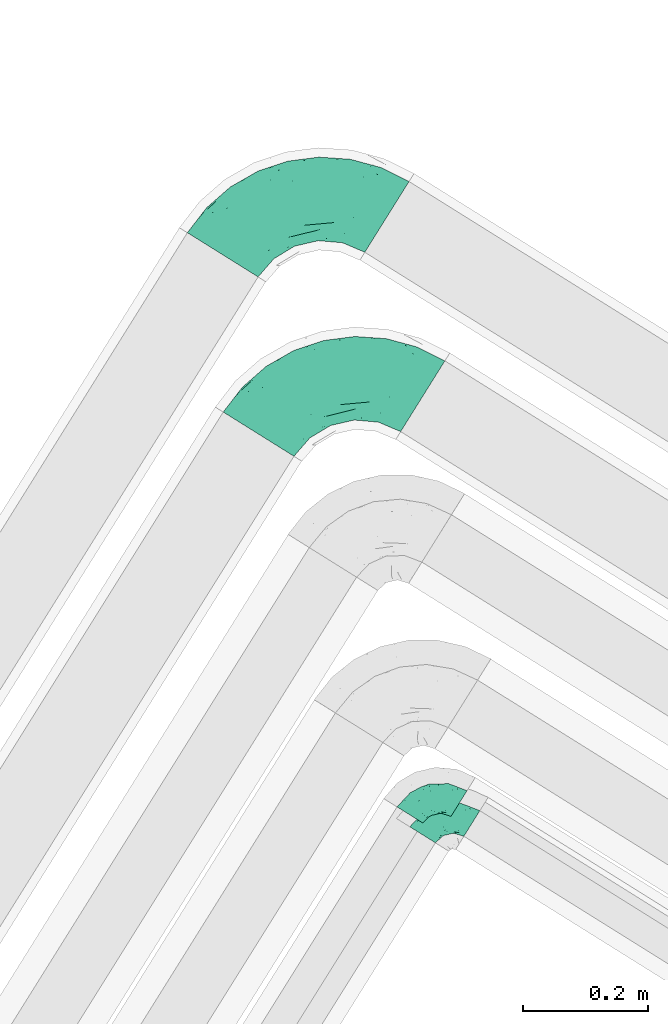
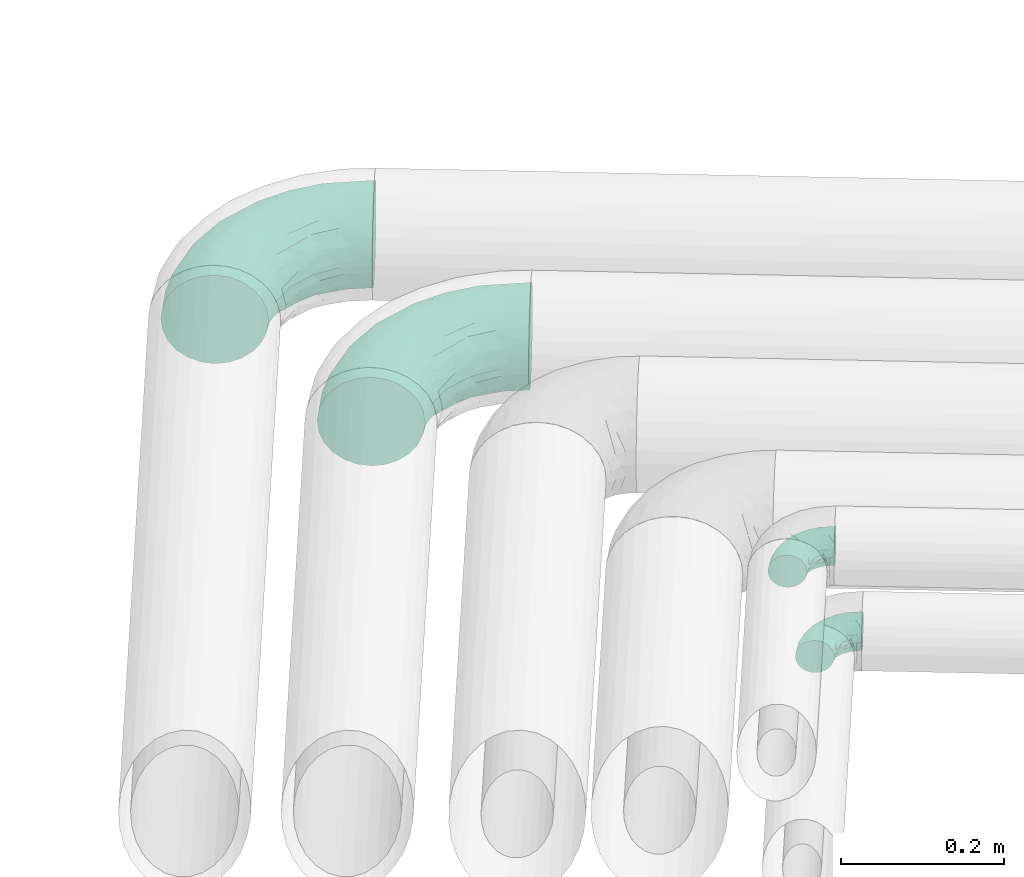
# One storey, part 63 of 93: 4 flow fittings.
"""IFC2X3 building model written with IfcOpenShell, lengths in millimetres."""

import ifcopenshell
import ifcopenshell.guid

model = None  # the IFC model being written
_history = None  # IfcOwnerHistory: only IFC2X3 demands one
_inside = {}  # id of a spatial element -> (the spatial element, [elements in it])
_under = {}  # id of a project, library or spatial element -> (it, [spatial elements below it])
_declared = {}  # id of a project -> (the project, [libraries it declares])
_typed = {}  # id of a type object -> (the type object, [elements of that type])
_made_of = {}  # id of a material, layer set ... -> (it, [elements and type objects made of it])


def new_model(schema):
    """Start an empty IFC model of exactly this schema.

    Asked for "IFC4X3", IfcOpenShell would pick the latest addendum, in which some entities
    have other attributes; the version numbers below select the first issue.
    IFC2X3 requires an IfcOwnerHistory on every rooted entity: one is made here for all.
    """
    global model, _history
    if schema == "IFC4X3":
        model = ifcopenshell.file(schema_version=(4, 3, 0, 0))
    else:
        model = ifcopenshell.file(schema=schema)
    _inside.clear()
    _under.clear()
    _declared.clear()
    _typed.clear()
    _made_of.clear()
    _history = None
    if model.schema == "IFC2X3":
        org = make("IfcOrganization", Name="unknown")
        user = make(
            "IfcPersonAndOrganization",
            ThePerson=make("IfcPerson", FamilyName="unknown"),
            TheOrganization=org,
        )
        app = make(
            "IfcApplication",
            ApplicationDeveloper=org,
            Version="unknown",
            ApplicationFullName="unknown",
            ApplicationIdentifier="unknown",
        )
        _history = make(
            "IfcOwnerHistory",
            OwningUser=user,
            OwningApplication=app,
            ChangeAction="ADDED",
            CreationDate=0,
        )
    return model


def make(cls, **values):
    """One entity of the class cls with the attributes given. An attribute that is None is left unset."""
    return model.create_entity(
        cls, **{name: value for name, value in values.items() if value is not None}
    )


def entity(cls, *values):
    """Any entity or typed value of the class cls, its attributes in the order of the schema. None: left unset."""
    e = model.create_entity(cls)
    for i, value in enumerate(values):
        if value is not None:
            e[i] = value
    return e


def rooted(cls, **values):
    """An entity with a GlobalId (a new one), such as an element, a storey or a relation."""
    return make(cls, GlobalId=ifcopenshell.guid.new(), OwnerHistory=_history, **values)


def si_unit(unit_type, name, prefix=None):
    """IfcSIUnit, for example si_unit("LENGTHUNIT", "METRE", prefix="MILLI")."""
    return make("IfcSIUnit", UnitType=unit_type, Prefix=prefix, Name=name)


def converted_unit(unit_type, name, factor, base, dimensions=None, offset=None):
    """IfcConversionBasedUnit, such as the inch: factor (a typed value) times the base unit."""
    return make(
        "IfcConversionBasedUnit"
        if offset is None
        else "IfcConversionBasedUnitWithOffset",
        ConversionOffset=offset,
        Dimensions=None
        if dimensions is None
        else entity("IfcDimensionalExponents", *dimensions),
        UnitType=unit_type,
        Name=name,
        ConversionFactor=make(
            "IfcMeasureWithUnit", ValueComponent=factor, UnitComponent=base
        ),
    )


def derived_unit(unit_type, elements):
    """IfcDerivedUnit: a product of units, each with its exponent."""
    return make(
        "IfcDerivedUnit",
        Elements=[
            make("IfcDerivedUnitElement", Unit=unit, Exponent=power)
            for unit, power in elements
        ],
        UnitType=unit_type,
    )


def assignment(units):
    """IfcUnitAssignment: the units of a project."""
    return None if units is None else make("IfcUnitAssignment", Units=units)


def point(xyz):
    """IfcCartesianPoint."""
    return None if xyz is None else make("IfcCartesianPoint", Coordinates=xyz)


def direction(xyz):
    """IfcDirection."""
    return None if xyz is None else make("IfcDirection", DirectionRatios=xyz)


def frame(location, z_axis=None, x_axis=None):
    """IfcAxis2Placement3D, a coordinate frame: its origin and axes. An axis left out is left unset."""
    return make(
        "IfcAxis2Placement3D",
        Location=point(location),
        Axis=direction(z_axis),
        RefDirection=direction(x_axis),
    )


def origin():
    """The frame at (0, 0, 0) with its axes left unset."""
    return frame((0.0, 0.0, 0.0))


def place(relative_to, where):
    """IfcLocalPlacement: puts the frame where relative to a parent placement (None: the world)."""
    return make(
        "IfcLocalPlacement", PlacementRelTo=relative_to, RelativePlacement=where
    )


def context(
    kind, dimensions, precision=None, world=None, true_north=None, identifier=None
):
    """IfcGeometricRepresentationContext, for example the 3D "Model" context."""
    return make(
        "IfcGeometricRepresentationContext",
        ContextIdentifier=identifier,
        ContextType=kind,
        CoordinateSpaceDimension=dimensions,
        Precision=precision,
        WorldCoordinateSystem=world,
        TrueNorth=true_north,
    )


def subcontext(parent, identifier, kind, view, scale=None):
    """IfcGeometricRepresentationSubContext, for example "Body" below "Model"."""
    return make(
        "IfcGeometricRepresentationSubContext",
        ContextIdentifier=identifier,
        ContextType=kind,
        ParentContext=parent,
        TargetScale=scale,
        TargetView=view,
    )


def project(units=None, contexts=None):
    """IfcProject with its units and contexts."""
    return rooted(
        "IfcProject",
        Name="project",
        RepresentationContexts=contexts,
        UnitsInContext=assignment(units),
    )


def spatial(cls, under=None, at=None, **own):
    """A site, building, storey or space (cls), placed at a placement, below another one or the project."""
    s = rooted(cls, ObjectPlacement=at, **own)
    if under is not None:
        _under.setdefault(under.id(), (under, []))[1].append(s)
    return s


def faces_of(points, faces, orient=None, outer=None):
    """IfcFace entities. A face is a list of loops; a loop is a list of indices into points, from 0.

    orient and outer hold one flag for each loop. By default every Orientation is true, the
    first loop of a face is its IfcFaceOuterBound and the others are IfcFaceBound.
    """
    made = []
    for i, loops in enumerate(faces):
        bounds = []
        for j, loop in enumerate(loops):
            is_outer = j == 0 if outer is None else outer[i][j]
            bounds.append(
                make(
                    "IfcFaceOuterBound" if is_outer else "IfcFaceBound",
                    Bound=make("IfcPolyLoop", Polygon=[points[k] for k in loop]),
                    Orientation=True if orient is None else orient[i][j],
                )
            )
        made.append(make("IfcFace", Bounds=bounds))
    return made


def faceted_brep(points, faces, orient=None, outer=None, voids=None):
    """IfcFacetedBrep: a solid bounded by flat faces; with voids (closed shells), ...WithVoids."""
    shared = [point(p) for p in points]
    hull = make("IfcClosedShell", CfsFaces=faces_of(shared, faces, orient, outer))
    if voids is None:
        return make("IfcFacetedBrep", Outer=hull)
    return make(
        "IfcFacetedBrepWithVoids",
        Outer=hull,
        Voids=[
            make(cls, CfsFaces=faces_of(shared, fs, o, b)) for cls, fs, o, b in voids
        ],
    )


def shape(context_of_items, identifier, shape_type, items):
    """IfcShapeRepresentation: the items that make up one representation, for example the "Body"."""
    return make(
        "IfcShapeRepresentation",
        ContextOfItems=context_of_items,
        RepresentationIdentifier=identifier,
        RepresentationType=shape_type,
        Items=items,
    )


def source(mapping_origin, context_of_items, identifier, shape_type, items):
    """IfcRepresentationMap: a shape defined once, which mapped items show again and again."""
    return make(
        "IfcRepresentationMap",
        MappingOrigin=mapping_origin,
        MappedRepresentation=shape(context_of_items, identifier, shape_type, items),
    )


def transform(
    local_origin,
    x_axis=None,
    y_axis=None,
    z_axis=None,
    scale=None,
    scale2=None,
    scale3=None,
    uniform=True,
):
    """IfcCartesianTransformationOperator3D, or its non-uniform kind. x_axis, y_axis, z_axis: its Axis1, 2, 3."""
    if uniform:
        return make(
            "IfcCartesianTransformationOperator3D",
            Axis1=direction(x_axis),
            Axis2=direction(y_axis),
            LocalOrigin=point(local_origin),
            Scale=scale,
            Axis3=direction(z_axis),
        )
    return make(
        "IfcCartesianTransformationOperator3DnonUniform",
        Axis1=direction(x_axis),
        Axis2=direction(y_axis),
        LocalOrigin=point(local_origin),
        Scale=scale,
        Axis3=direction(z_axis),
        Scale2=scale2,
        Scale3=scale3,
    )


def mapped(mapping_source, mapping_target):
    """IfcMappedItem: shows the shape of a source again, moved by a transform."""
    return make(
        "IfcMappedItem", MappingSource=mapping_source, MappingTarget=mapping_target
    )


def material(Name=None, Category=None):
    """IfcMaterial."""
    return make("IfcMaterial", Name=Name, Category=Category)


def made_of(thing, what):
    """Note that an element or type object is made of a material, layer set ...; save() writes the relation."""
    if what is not None:
        _made_of.setdefault(what.id(), (what, []))[1].append(thing)
    return thing


def type_object(cls, material=None, **own):
    """A type object (cls), such as IfcWallType, which elements share."""
    return made_of(rooted(cls, **own), material)


def type_shapes(of_type, sources):
    """Give a type object the sources (RepresentationMaps) that its elements show as mapped items."""
    of_type.RepresentationMaps = sources


def element(
    cls,
    number,
    at=None,
    inside=None,
    cuts=None,
    type_object=None,
    material=None,
    context=None,
    identifier="Body",
    shape_type=None,
    held_by="IfcProductDefinitionShape",
    body=None,
    shapes=None,
    **own,
):
    """One element of the class cls, such as IfcWall. Its Tag is "e" and its number.

    at: its placement. inside: the storey or other place that contains it. cuts: it is an
    opening in that element (IfcRelVoidsElement). A single representation is given by context,
    identifier, shape_type and body (its items); several are given by shapes. held_by: the class
    of the entity that holds the representations. save() writes the other relations.
    """
    e = rooted(cls, Tag="e%d" % number, ObjectPlacement=at, **own)
    if body is not None:
        shapes = [shape(context, identifier, shape_type, body)]
    if shapes is not None:
        e.Representation = make(held_by, Representations=shapes)
    if inside is not None:
        _inside.setdefault(inside.id(), (inside, []))[1].append(e)
    if cuts is not None:
        rooted(
            "IfcRelVoidsElement", RelatingBuildingElement=cuts, RelatedOpeningElement=e
        )
    if type_object is not None:
        _typed.setdefault(type_object.id(), (type_object, []))[1].append(e)
    return made_of(e, material)


def aggregate(whole, parts):
    """IfcRelAggregates: a whole, such as a stair, and the parts it consists of."""
    return rooted("IfcRelAggregates", RelatingObject=whole, RelatedObjects=parts)


def save(model, path):
    """Write the relations noted so far, then the file.

    IfcRelAggregates (storeys below a building ...), IfcRelContainedInSpatialStructure (elements
    in a storey), IfcRelDefinesByType, IfcRelAssociatesMaterial and IfcRelDeclares: one each for
    every whole, place, type object, material and project.
    """
    for whole, parts in _under.values():
        aggregate(whole, parts)
    for where, things in _inside.values():
        rooted(
            "IfcRelContainedInSpatialStructure",
            RelatedElements=things,
            RelatingStructure=where,
        )
    for kind, things in _typed.values():
        rooted("IfcRelDefinesByType", RelatedObjects=things, RelatingType=kind)
    for what, things in _made_of.values():
        rooted("IfcRelAssociatesMaterial", RelatedObjects=things, RelatingMaterial=what)
    for by, libraries in _declared.values():
        rooted("IfcRelDeclares", RelatingContext=by, RelatedDefinitions=libraries)
    model.write(path)


model = new_model("IFC2X3")

# Units and contexts
model_context = context("Model", 3, precision=0.01, world=origin(), true_north=direction((6.12303176911189e-17, 1.0)))
body_context = subcontext(model_context, "Body", "Model", "MODEL_VIEW")
ifc_project = project(units=[si_unit("LENGTHUNIT", "METRE", prefix="MILLI"), si_unit("AREAUNIT", "SQUARE_METRE"), si_unit("VOLUMEUNIT", "CUBIC_METRE"), converted_unit("PLANEANGLEUNIT", "DEGREE", entity("IfcRatioMeasure", 0.0174532925199433), si_unit("PLANEANGLEUNIT", "RADIAN"), dimensions=[0, 0, 0, 0, 0, 0, 0]), si_unit("MASSUNIT", "GRAM", prefix="KILO"), derived_unit("MASSDENSITYUNIT", [(si_unit("MASSUNIT", "GRAM", prefix="KILO"), 1), (si_unit("LENGTHUNIT", "METRE"), -3)]), derived_unit("MOMENTOFINERTIAUNIT", [(si_unit("LENGTHUNIT", "METRE"), 4)]), si_unit("TIMEUNIT", "SECOND"), si_unit("FREQUENCYUNIT", "HERTZ"), si_unit("THERMODYNAMICTEMPERATUREUNIT", "DEGREE_CELSIUS"), derived_unit("THERMALTRANSMITTANCEUNIT", [(si_unit("MASSUNIT", "GRAM", prefix="KILO"), 1), (si_unit("THERMODYNAMICTEMPERATUREUNIT", "KELVIN"), -1), (si_unit("TIMEUNIT", "SECOND"), -3)]), derived_unit("VOLUMETRICFLOWRATEUNIT", [(si_unit("LENGTHUNIT", "METRE"), 3), (si_unit("TIMEUNIT", "SECOND"), -1)]), derived_unit("MASSFLOWRATEUNIT", [(si_unit("MASSUNIT", "GRAM", prefix="KILO"), 1), (si_unit("TIMEUNIT", "SECOND"), -1)]), derived_unit("ROTATIONALFREQUENCYUNIT", [(si_unit("TIMEUNIT", "SECOND"), -1)]), si_unit("ELECTRICCURRENTUNIT", "AMPERE"), si_unit("ELECTRICVOLTAGEUNIT", "VOLT"), si_unit("POWERUNIT", "WATT"), si_unit("FORCEUNIT", "NEWTON", prefix="KILO"), si_unit("ILLUMINANCEUNIT", "LUX"), si_unit("LUMINOUSFLUXUNIT", "LUMEN"), si_unit("LUMINOUSINTENSITYUNIT", "CANDELA"), derived_unit("USERDEFINED", [(si_unit("MASSUNIT", "GRAM", prefix="KILO"), -1), (si_unit("LENGTHUNIT", "METRE"), -2), (si_unit("TIMEUNIT", "SECOND"), 3), (si_unit("LUMINOUSFLUXUNIT", "LUMEN"), 1)]), derived_unit("LINEARVELOCITYUNIT", [(si_unit("LENGTHUNIT", "METRE"), 1), (si_unit("TIMEUNIT", "SECOND"), -1)]), si_unit("PRESSUREUNIT", "PASCAL"), derived_unit("USERDEFINED", [(si_unit("LENGTHUNIT", "METRE"), -2), (si_unit("MASSUNIT", "GRAM", prefix="KILO"), 1), (si_unit("TIMEUNIT", "SECOND"), -2)]), derived_unit("LINEARFORCEUNIT", [(si_unit("MASSUNIT", "GRAM", prefix="KILO"), 1), (si_unit("LENGTHUNIT", "METRE"), 1), (si_unit("TIMEUNIT", "SECOND"), -2), (si_unit("LENGTHUNIT", "METRE"), -1)]), derived_unit("PLANARFORCEUNIT", [(si_unit("MASSUNIT", "GRAM", prefix="KILO"), 1), (si_unit("LENGTHUNIT", "METRE"), 1), (si_unit("TIMEUNIT", "SECOND"), -2), (si_unit("LENGTHUNIT", "METRE"), -2)])], contexts=[model_context])

# Site, building, storey
site_placement = place(None, origin())
site = spatial("IfcSite", under=ifc_project, at=site_placement, CompositionType="ELEMENT")
building_placement = place(site_placement, origin())
building = spatial("IfcBuilding", under=site, at=building_placement, CompositionType="ELEMENT")
storey_placement = place(building_placement, frame((0.0, 0.0, -4200.0)))
storey = spatial("IfcBuildingStorey", under=building, at=storey_placement, CompositionType="ELEMENT", Elevation=-4200.0)

# Flow fittings
ifc_material = material()
pipe_fitting_type_1 = type_object("IfcPipeFittingType", Name="ADSK_2", PredefinedType="NOTDEFINED", material=ifc_material)
shared_shape_1 = source(origin(), body_context, "Body", "Brep", [
    faceted_brep([(-190.0, 33.25, -57.59), (-190.0, 17.21, -64.23), (-190.0, 0.0, -66.5), (-190.0, -17.21, -64.23), (-190.0, -33.25, -57.59), (-190.0, -47.02, -47.02), (-190.0, -57.59, -33.25), (-190.0, -64.23, -17.21), (-190.0, -66.5, 0.0), (-190.0, -64.23, 17.21), (-190.0, -57.59, 33.25), (-190.0, -47.02, 47.02), (-190.0, -33.25, 57.59), (-190.0, -17.21, 64.23), (-190.0, 0.0, 66.5), (-190.0, 17.21, 64.23), (-190.0, 33.25, 57.59), (-190.0, 47.02, 47.02), (-190.0, 57.59, 33.25), (-190.0, 64.23, 17.21), (-190.0, 66.5, 0.0), (-190.0, 64.23, -17.21), (-190.0, 57.59, -33.25), (-190.0, 47.02, -47.02), (0.0, 190.0, -66.5), (-17.21, 190.0, -64.23), (-33.25, 190.0, -57.59), (-47.02, 190.0, -47.02), (-57.59, 190.0, -33.25), (-64.23, 190.0, -17.21), (-66.5, 190.0, 0.0), (-64.23, 190.0, 17.21), (-57.59, 190.0, 33.25), (-47.02, 190.0, 47.02), (-33.25, 190.0, 57.59), (-17.21, 190.0, 64.23), (0.0, 190.0, 66.5), (17.21, 190.0, 64.23), (33.25, 190.0, 57.59), (47.02, 190.0, 47.02), (57.59, 190.0, 33.25), (64.23, 190.0, 17.21), (66.5, 190.0, 0.0), (64.23, 190.0, -17.21), (57.59, 190.0, -33.25), (47.02, 190.0, -47.02), (33.25, 190.0, -57.59), (17.21, 190.0, -64.23), (-28.55, 147.02, 62.42), (-13.57, 135.63, 66.28), (-140.38, -49.33, 38.23), (-80.14, -30.55, 35.23), (-124.14, -33.9, 50.4), (-141.11, -22.46, 60.31), (-81.84, -6.19, 57.13), (-101.3, 6.38, 65.03), (-125.04, -54.28, 21.95), (-139.96, -61.57, 0.0), (-30.59, -6.47, 21.28), (-47.5, -23.27, 0.0), (-8.63, 8.63, 0.0), (-101.64, 52.37, 61.01), (-147.02, 28.55, 62.42), (-107.01, 35.47, 64.88), (-72.79, -35.94, 16.05), (-91.84, -46.98, 0.0), (-42.05, -7.73, 34.33), (-4.24, 27.9, 35.0), (-46.26, 0.22, 45.96), (-148.38, -6.74, 65.57), (-135.63, 13.57, 66.28), (-58.81, 143.49, 42.9), (-64.43, 158.86, 27.32), (33.87, 124.03, 50.39), (-24.86, 95.88, 66.5), (-6.38, 101.3, 65.03), (-68.44, 29.45, 65.52), (-33.12, 50.38, 63.42), (-47.55, 58.11, 66.37), (-68.78, 157.93, 15.75), (-78.73, 128.81, 21.25), (-145.19, 58.3, 42.81), (-126.57, 73.12, 34.22), (-158.86, 64.43, 27.32), (-157.93, 68.78, 15.75), (-73.06, 126.96, 34.0), (-99.23, 99.23, 24.99), (-94.51, 94.51, 37.44), (-160.28, 41.89, 53.91), (-151.84, 72.54, 0.0), (-128.81, 78.73, 21.25), (-117.41, 90.09, 0.0), (7.42, 29.34, 16.05), (36.05, 72.53, 15.16), (23.27, 47.5, 0.0), (30.73, 80.34, 35.12), (61.57, 139.96, 0.0), (62.07, 150.38, 13.25), (46.98, 91.84, 0.0), (22.46, 141.08, 60.31), (6.16, 81.82, 57.15), (-39.4, 100.2, 64.86), (54.07, 123.33, 21.27), (49.32, 140.35, 38.22), (-83.36, -19.52, 48.87), (6.74, 148.38, 65.57), (-85.07, 81.39, 53.88), (-123.92, 51.92, 55.31), (-90.09, 117.41, 0.0), (-72.54, 151.84, 0.0), (-101.92, 101.92, 11.85), (-42.36, 157.28, 54.02), (-54.08, 118.94, 55.5), (-1.97, 47.81, 48.28), (22.27, 83.36, 46.49), (-79.1, 73.18, 59.88), (-73.69, 63.3, 64.01), (-96.26, 24.55, 66.5), (-73.56, 111.53, 44.32), (-111.08, 72.88, 45.21), (-31.39, 31.39, 56.96), (-71.89, 12.15, 62.21), (-42.48, 117.92, 61.28), (-157.28, 42.36, -54.02), (-72.79, -35.94, -16.05), (-44.48, -10.39, -33.14), (-30.59, -6.47, -21.28), (-101.3, 6.38, -65.03), (-148.38, -6.74, -65.57), (-135.63, 13.57, -66.28), (-157.93, 68.78, -15.75), (-128.81, 78.73, -21.25), (-158.86, 64.43, -27.32), (-147.02, 28.55, -62.42), (-100.2, 39.4, -64.86), (-95.88, 24.86, -66.5), (-150.3, -62.06, -13.27), (-101.92, 101.92, -11.85), (-143.49, 58.81, -42.9), (6.74, 148.38, -65.57), (-13.57, 135.63, -66.28), (-52.37, 101.64, -61.01), (-81.39, 85.07, -53.88), (-51.92, 123.92, -55.31), (-124.14, -33.9, -50.4), (-81.84, -6.19, -57.13), (-78.6, -18.73, -47.44), (-140.38, -49.33, -38.23), (-24.55, 96.26, -66.5), (-35.47, 107.01, -64.88), (-28.55, 147.02, -62.42), (-80.14, -30.55, -35.23), (-123.37, -54.04, -21.36), (-64.43, 158.86, -27.32), (-68.78, 157.93, -15.75), (-73.18, 79.1, -59.88), (-63.3, 73.69, -64.01), (-29.45, 68.44, -65.52), (-50.38, 33.12, -63.42), (-58.11, 47.55, -66.37), (-78.73, 128.81, -21.25), (-99.23, 99.23, -24.99), (-126.96, 73.06, -34.0), (-94.51, 94.51, -37.44), (-58.3, 145.19, -42.81), (-73.12, 126.57, -34.22), (-118.94, 54.08, -55.5), (-41.89, 160.28, -53.91), (22.46, 141.08, -60.31), (6.16, 81.82, -57.15), (-6.38, 101.3, -65.03), (33.87, 124.03, -50.39), (54.35, 125.32, -21.97), (35.86, 72.99, -16.69), (49.34, 140.46, -38.23), (7.54, 29.16, -15.21), (-141.11, -22.46, -60.31), (30.73, 80.34, -35.12), (22.8, 84.14, -46.35), (-4.38, 23.43, -29.89), (5.33, 47.62, -41.81), (-111.53, 73.56, -44.32), (-72.88, 111.08, -45.21), (-48.51, 2.91, -49.35), (-20.15, 28.66, -49.63), (-27.46, 10.86, -41.59), (-12.16, 71.91, -62.22), (2.48, 58.84, -50.8), (-117.92, 42.48, -61.28), (-31.39, 31.39, -56.96)], [[[0, 1, 2, 3, 4, 5, 6, 7, 8, 9, 10, 11, 12, 13, 14, 15, 16, 17, 18, 19, 20, 21, 22, 23]], [[24, 25, 26, 27, 28, 29, 30, 31, 32, 33, 34, 35, 36, 37, 38, 39, 40, 41, 42, 43, 44, 45, 46, 47]], [[35, 48, 49]], [[50, 51, 52]], [[53, 54, 55]], [[56, 10, 9]], [[9, 8, 57]], [[58, 59, 60]], [[56, 50, 10]], [[61, 62, 63]], [[64, 65, 59]], [[58, 64, 59]], [[12, 11, 52]], [[66, 67, 68]], [[52, 53, 12]], [[69, 70, 14]], [[71, 32, 72]], [[73, 39, 38]], [[49, 74, 75]], [[62, 16, 15]], [[14, 70, 15]], [[72, 32, 31]], [[13, 69, 14]], [[76, 77, 78]], [[79, 80, 72]], [[81, 82, 83]], [[62, 15, 70]], [[20, 19, 84]], [[85, 86, 87]], [[81, 17, 88]], [[89, 90, 91]], [[19, 83, 84]], [[16, 88, 17]], [[85, 71, 72]], [[58, 60, 92]], [[49, 36, 35]], [[93, 92, 94]], [[35, 34, 48]], [[92, 93, 95]], [[96, 97, 98]], [[73, 99, 100]], [[49, 101, 74]], [[102, 97, 40]], [[39, 73, 103]], [[95, 102, 103]], [[40, 39, 103]], [[12, 53, 13]], [[68, 54, 104]], [[42, 97, 96]], [[41, 97, 42]], [[99, 38, 37]], [[37, 36, 105]], [[61, 106, 107]], [[108, 80, 109]], [[10, 50, 11]], [[108, 91, 110]], [[109, 79, 30]], [[64, 51, 56]], [[71, 33, 32]], [[86, 110, 90]], [[92, 60, 94]], [[111, 34, 33]], [[71, 112, 111]], [[49, 48, 101]], [[9, 57, 56]], [[17, 81, 18]], [[65, 56, 57]], [[113, 114, 100]], [[75, 105, 49]], [[115, 61, 116]], [[58, 92, 67]], [[99, 73, 38]], [[70, 117, 63]], [[18, 83, 19]], [[71, 85, 118]], [[119, 107, 106]], [[83, 82, 90]], [[51, 50, 56]], [[52, 11, 50]], [[51, 64, 58]], [[56, 65, 64]], [[94, 98, 93]], [[67, 92, 95]], [[95, 114, 113]], [[68, 120, 54]], [[54, 53, 52]], [[69, 53, 55]], [[104, 51, 68]], [[121, 76, 55]], [[103, 73, 114]], [[102, 40, 103]], [[105, 99, 37]], [[75, 77, 100]], [[75, 100, 99]], [[100, 120, 113]], [[111, 48, 34]], [[115, 101, 122]], [[122, 101, 48]], [[101, 116, 78]], [[116, 63, 117]], [[78, 117, 76]], [[63, 62, 70]], [[88, 62, 107]], [[98, 102, 93]], [[95, 93, 102]], [[66, 68, 51]], [[113, 68, 67]], [[49, 105, 36]], [[99, 105, 75]], [[53, 69, 13]], [[70, 69, 55]], [[70, 55, 117]], [[61, 63, 116]], [[76, 117, 55]], [[116, 117, 78]], [[121, 55, 54]], [[76, 121, 77]], [[100, 77, 120]], [[75, 78, 77]], [[54, 120, 121]], [[77, 121, 120]], [[71, 111, 33]], [[111, 112, 122]], [[68, 113, 120]], [[95, 113, 67]], [[61, 115, 106]], [[62, 61, 107]], [[118, 112, 71]], [[119, 87, 82]], [[101, 115, 116]], [[112, 106, 115]], [[79, 72, 31]], [[72, 80, 85]], [[86, 85, 80]], [[118, 85, 87]], [[119, 118, 87]], [[112, 118, 106]], [[30, 79, 31]], [[109, 80, 79]], [[81, 83, 18]], [[84, 83, 90]], [[119, 82, 81]], [[86, 82, 87]], [[107, 119, 81]], [[118, 119, 106]], [[90, 89, 84]], [[20, 84, 89]], [[62, 88, 16]], [[81, 88, 107]], [[101, 78, 74]], [[78, 75, 74]], [[80, 108, 110]], [[82, 86, 90]], [[90, 110, 91]], [[80, 110, 86]], [[40, 97, 41]], [[98, 97, 102]], [[111, 122, 48]], [[115, 122, 112]], [[54, 52, 104]], [[51, 104, 52]], [[51, 58, 66]], [[67, 66, 58]], [[103, 114, 95]], [[100, 114, 73]], [[23, 123, 0]], [[124, 125, 126]], [[127, 128, 129]], [[130, 131, 132]], [[133, 134, 129]], [[129, 135, 127]], [[89, 130, 20]], [[8, 136, 57]], [[91, 131, 89]], [[59, 65, 124]], [[108, 137, 91]], [[132, 22, 21]], [[138, 23, 22]], [[139, 140, 24]], [[141, 142, 143]], [[144, 145, 146]], [[5, 144, 147]], [[140, 148, 149]], [[8, 7, 136]], [[138, 22, 132]], [[6, 5, 147]], [[141, 150, 149]], [[147, 151, 152]], [[152, 136, 6]], [[29, 153, 154]], [[125, 124, 151]], [[136, 65, 57]], [[155, 141, 156]], [[128, 3, 2]], [[126, 59, 124]], [[129, 134, 135]], [[157, 158, 159]], [[160, 161, 137]], [[1, 0, 133]], [[129, 2, 1]], [[162, 138, 132]], [[161, 163, 162]], [[154, 30, 29]], [[144, 5, 4]], [[153, 164, 165]], [[150, 26, 25]], [[166, 123, 138]], [[24, 47, 139]], [[24, 140, 25]], [[28, 153, 29]], [[26, 167, 27]], [[168, 169, 170]], [[140, 150, 25]], [[27, 164, 28]], [[46, 171, 168]], [[172, 98, 173]], [[59, 126, 60]], [[27, 167, 164]], [[44, 174, 45]], [[173, 98, 94]], [[175, 173, 94]], [[176, 144, 4]], [[171, 46, 45]], [[44, 43, 172]], [[43, 96, 172]], [[42, 96, 43]], [[144, 146, 151]], [[144, 176, 145]], [[177, 178, 174]], [[173, 175, 179]], [[44, 172, 174]], [[98, 172, 96]], [[1, 133, 129]], [[179, 180, 177]], [[109, 160, 108]], [[46, 168, 47]], [[176, 4, 3]], [[138, 162, 181]], [[182, 143, 142]], [[153, 165, 160]], [[94, 60, 175]], [[177, 172, 173]], [[151, 147, 144]], [[152, 6, 147]], [[128, 176, 3]], [[127, 158, 145]], [[127, 145, 176]], [[183, 184, 185]], [[65, 152, 124]], [[151, 124, 152]], [[177, 174, 172]], [[171, 45, 174]], [[169, 168, 171]], [[139, 168, 170]], [[178, 177, 180]], [[186, 157, 170]], [[187, 169, 178]], [[126, 179, 175]], [[123, 133, 0]], [[155, 134, 188]], [[188, 134, 133]], [[134, 156, 159]], [[156, 149, 148]], [[159, 148, 157]], [[149, 150, 140]], [[167, 150, 143]], [[60, 126, 175]], [[125, 179, 126]], [[129, 128, 2]], [[176, 128, 127]], [[168, 139, 47]], [[140, 139, 170]], [[140, 170, 148]], [[141, 149, 156]], [[157, 148, 170]], [[156, 148, 159]], [[186, 170, 169]], [[157, 186, 158]], [[145, 158, 189]], [[127, 159, 158]], [[169, 189, 186]], [[158, 186, 189]], [[180, 179, 185]], [[173, 179, 177]], [[187, 184, 189]], [[178, 171, 174]], [[187, 178, 180]], [[169, 171, 178]], [[184, 180, 185]], [[189, 169, 187]], [[138, 123, 23]], [[123, 166, 188]], [[141, 155, 142]], [[150, 141, 143]], [[181, 166, 138]], [[182, 163, 165]], [[134, 155, 156]], [[166, 142, 155]], [[130, 132, 21]], [[132, 131, 162]], [[161, 162, 131]], [[181, 162, 163]], [[182, 181, 163]], [[166, 181, 142]], [[20, 130, 21]], [[89, 131, 130]], [[164, 153, 28]], [[154, 153, 160]], [[182, 165, 164]], [[161, 165, 163]], [[143, 182, 164]], [[181, 182, 142]], [[160, 109, 154]], [[30, 154, 109]], [[150, 167, 26]], [[164, 167, 143]], [[134, 159, 135]], [[159, 127, 135]], [[131, 91, 137]], [[165, 161, 160]], [[160, 137, 108]], [[131, 137, 161]], [[6, 136, 7]], [[65, 136, 152]], [[183, 189, 184]], [[146, 183, 125]], [[146, 125, 151]], [[179, 125, 185]], [[123, 188, 133]], [[155, 188, 166]], [[180, 184, 187]], [[185, 125, 183]], [[146, 145, 183]], [[189, 183, 145]]]),
])
type_shapes(pipe_fitting_type_1, [shared_shape_1])
for number, where, z_axis, x_axis, name in (
    (1, (16045.0, 11592.98, 3000.0), (0.0, 0.0, 1.0), (-0.848048096156425, 0.529919264233207, 0.0), "ADSK_2"),
    (2, (15987.85, 11878.94, 3000.0), (0.0, 0.0, 1.0), (-0.848048096156422, 0.529919264233211, 0.0), "ADSK_2"),
):
    element("IfcFlowFitting", number, at=place(storey_placement, frame(where, z_axis=z_axis, x_axis=x_axis)), inside=storey, type_object=pipe_fitting_type_1, material=ifc_material, Name=name, ObjectType="ADSK_2", context=body_context, shape_type="MappedRepresentation", body=[
        mapped(shared_shape_1, transform((0.0, 0.0, 0.0), scale=1.0)),
    ])
pipe_fitting_type_2 = type_object("IfcPipeFittingType", Name="ADSK_1", PredefinedType="NOTDEFINED", material=ifc_material)
shared_shape_2 = source(origin(), body_context, "Body", "Brep", [
    faceted_brep([(-57.0, 12.07, -20.91), (-57.0, 6.25, -23.33), (-57.0, 0.0, -24.15), (-57.0, -6.25, -23.33), (-57.0, -12.08, -20.91), (-57.0, -17.08, -17.08), (-57.0, -20.91, -12.08), (-57.0, -23.33, -6.25), (-57.0, -24.15, 0.0), (-57.0, -23.33, 6.25), (-57.0, -20.91, 12.07), (-57.0, -17.08, 17.08), (-57.0, -12.08, 20.91), (-57.0, -6.25, 23.33), (-57.0, 0.0, 24.15), (-57.0, 6.25, 23.33), (-57.0, 12.07, 20.91), (-57.0, 17.08, 17.08), (-57.0, 20.91, 12.07), (-57.0, 23.33, 6.25), (-57.0, 24.15, 0.0), (-57.0, 23.33, -6.25), (-57.0, 20.91, -12.08), (-57.0, 17.08, -17.08), (0.0, 57.0, -24.15), (-6.25, 57.0, -23.33), (-12.07, 57.0, -20.91), (-17.08, 57.0, -17.08), (-20.91, 57.0, -12.08), (-23.33, 57.0, -6.25), (-24.15, 57.0, 0.0), (-23.33, 57.0, 6.25), (-20.91, 57.0, 12.07), (-17.08, 57.0, 17.08), (-12.07, 57.0, 20.91), (-6.25, 57.0, 23.33), (0.0, 57.0, 24.15), (6.25, 57.0, 23.33), (12.08, 57.0, 20.91), (17.08, 57.0, 17.08), (20.91, 57.0, 12.07), (23.33, 57.0, 6.25), (24.15, 57.0, 0.0), (23.33, 57.0, -6.25), (20.91, 57.0, -12.08), (17.08, 57.0, -17.08), (12.08, 57.0, -20.91), (6.25, 57.0, -23.33), (14.9, 21.14, 6.17), (13.61, 24.64, 12.48), (6.23, 8.95, 8.98), (-41.47, -21.06, 0.0), (-41.92, -18.38, 13.72), (-24.64, -13.61, 12.48), (-37.37, -13.24, 18.15), (-6.8, -4.93, 8.18), (-21.76, -15.19, 6.22), (-12.78, -9.18, 0.0), (-37.73, -20.51, 7.75), (-7.38, 7.38, 20.24), (-23.37, -4.26, 20.42), (-11.9, -3.19, 15.86), (-42.14, -8.7, 21.82), (13.24, 37.37, 18.15), (9.33, 23.53, 16.85), (4.26, 23.37, 20.42), (2.77, 10.92, 15.55), (-29.46, 0.91, 23.52), (-44.13, 20.56, 15.69), (-39.25, 26.33, 10.88), (-49.02, 22.92, 9.96), (-34.58, 23.87, 17.15), (-15.8, 6.8, 22.81), (-8.67, 20.47, 23.88), (-18.12, 12.9, 24.08), (-48.29, 14.92, 19.65), (-44.06, -2.85, 23.78), (-9.23, 48.95, 22.58), (-3.78, 42.74, 24.07), (-40.34, 4.26, 24.09), (-44.02, 26.14, 5.46), (-44.04, 9.88, 22.74), (-4.95, 16.87, 22.52), (-2.75, 1.43, 12.5), (-25.48, 40.98, 10.71), (20.51, 37.73, 7.75), (18.38, 41.92, 13.72), (8.7, 42.14, 21.82), (-25.95, -17.97, 0.0), (2.85, 44.06, 23.78), (21.06, 41.47, 0.0), (17.97, 25.95, 0.0), (-24.04, -9.27, 17.13), (-33.26, 33.26, 5.86), (-28.55, 40.57, 0.0), (-40.57, 28.55, 0.0), (-25.29, 47.19, 4.06), (-27.01, 31.1, 16.77), (-15.7, 43.95, 19.9), (-20.27, 45.22, 15.61), (-30.53, 31.98, 12.64), (-11.28, 38.33, 22.92), (-9.97, 27.88, 24.09), (-20.15, 30.26, 21.25), (-31.25, 11.75, 23.64), (-28.75, 7.23, 24.15), (-29.53, 18.06, 22.27), (-28.44, 24.21, 20.02), (-37.55, 17.7, 20.26), (-15.88, 29.25, 22.99), (-20.82, 20.82, 23.44), (-0.91, 29.46, 23.52), (-13.5, -7.67, 12.04), (1.49, 1.56, 5.16), (8.86, 10.35, 4.59), (0.38, -0.38, 0.0), (9.18, 12.78, 0.0), (-37.37, -13.24, -18.15), (8.86, 10.35, -4.59), (-45.22, 20.27, -15.61), (-43.95, 15.7, -19.9), (-38.33, 11.28, -22.92), (-48.95, 9.23, -22.58), (-47.19, 25.29, -4.06), (-33.26, 33.26, -5.86), (18.38, 41.92, -13.72), (-30.26, 20.15, -21.25), (2.85, 44.06, -23.78), (-4.26, 40.34, -24.09), (-40.98, 25.48, -10.71), (-41.92, -18.38, -13.72), (9.25, 23.5, -16.92), (4.26, 23.37, -20.42), (13.24, 37.37, -18.15), (-37.73, -20.51, -7.75), (-11.75, 31.25, -23.64), (-7.23, 28.75, -24.15), (-12.9, 18.12, -24.08), (8.7, 42.14, -21.82), (-44.06, -2.85, -23.78), (-6.8, 15.8, -22.81), (-20.47, 8.67, -23.88), (-24.64, -13.61, -12.48), (-42.74, 3.78, -24.07), (-18.06, 29.53, -22.27), (-24.21, 28.44, -20.02), (-27.88, 9.97, -24.09), (-31.1, 27.01, -16.77), (-26.14, 44.02, -5.46), (14.9, 21.14, -6.17), (20.51, 37.73, -7.75), (-9.88, 44.04, -22.74), (-20.56, 44.13, -15.69), (-21.76, -15.19, -6.22), (-13.5, -7.67, -12.04), (-24.14, -9.76, -16.74), (-11.9, -3.19, -15.86), (-14.92, 48.29, -19.65), (-23.37, -4.26, -20.42), (-0.91, 29.46, -23.52), (-26.33, 39.25, -10.88), (-23.87, 34.58, -17.15), (-42.14, -8.7, -21.82), (-22.92, 49.02, -9.96), (13.61, 24.64, -12.48), (-31.98, 30.53, -12.64), (-16.87, 4.95, -22.52), (-17.7, 37.55, -20.26), (-29.25, 15.88, -22.99), (-20.82, 20.82, -23.44), (-29.46, 0.91, -23.52), (-7.38, 7.38, -20.24), (2.77, 10.92, -15.55), (6.23, 8.95, -8.98), (-6.8, -4.93, -8.18), (-2.81, 1.41, -12.54), (1.49, 1.56, -5.16)], [[[0, 1, 2, 3, 4, 5, 6, 7, 8, 9, 10, 11, 12, 13, 14, 15, 16, 17, 18, 19, 20, 21, 22, 23]], [[24, 25, 26, 27, 28, 29, 30, 31, 32, 33, 34, 35, 36, 37, 38, 39, 40, 41, 42, 43, 44, 45, 46, 47]], [[48, 49, 50]], [[9, 8, 51]], [[52, 53, 54]], [[55, 56, 57]], [[10, 58, 52]], [[9, 58, 10]], [[59, 60, 61]], [[54, 12, 11]], [[54, 62, 12]], [[63, 39, 38]], [[64, 65, 66]], [[62, 60, 67]], [[68, 69, 70]], [[71, 69, 68]], [[72, 73, 74]], [[16, 75, 17]], [[13, 76, 14]], [[35, 77, 78]], [[14, 79, 15]], [[17, 68, 18]], [[14, 76, 79]], [[20, 19, 80]], [[70, 19, 18]], [[81, 15, 79]], [[15, 81, 16]], [[73, 72, 82]], [[66, 83, 50]], [[32, 31, 84]], [[85, 86, 49]], [[63, 87, 65]], [[56, 58, 88]], [[36, 89, 37]], [[85, 41, 40]], [[36, 35, 78]], [[90, 41, 85]], [[40, 39, 86]], [[12, 62, 13]], [[86, 85, 40]], [[48, 85, 49]], [[85, 91, 90]], [[87, 38, 37]], [[92, 60, 54]], [[80, 69, 93]], [[93, 94, 95]], [[10, 52, 11]], [[94, 96, 30]], [[97, 98, 99]], [[80, 93, 95]], [[100, 97, 84]], [[99, 98, 33]], [[101, 102, 78]], [[103, 101, 98]], [[96, 31, 30]], [[77, 98, 101]], [[77, 35, 34]], [[34, 33, 98]], [[9, 51, 58]], [[87, 63, 38]], [[104, 105, 74]], [[106, 103, 107]], [[106, 81, 104]], [[75, 68, 17]], [[108, 107, 71]], [[33, 32, 99]], [[109, 103, 110]], [[101, 109, 102]], [[89, 78, 111]], [[53, 52, 58]], [[54, 11, 52]], [[60, 62, 54]], [[88, 58, 51]], [[76, 62, 67]], [[53, 112, 92]], [[60, 59, 72]], [[39, 63, 86]], [[49, 86, 63]], [[89, 87, 37]], [[42, 41, 90]], [[111, 82, 65]], [[111, 65, 87]], [[65, 59, 66]], [[104, 81, 79]], [[75, 81, 108]], [[32, 84, 99]], [[97, 99, 84]], [[98, 97, 103]], [[106, 107, 108]], [[74, 102, 110]], [[111, 78, 102]], [[74, 110, 104]], [[74, 67, 72]], [[61, 92, 112]], [[66, 59, 61]], [[56, 53, 58]], [[66, 50, 49]], [[61, 112, 83]], [[66, 49, 64]], [[78, 89, 36]], [[87, 89, 111]], [[62, 76, 13]], [[79, 76, 67]], [[100, 93, 69]], [[96, 93, 84]], [[55, 113, 50]], [[113, 114, 50]], [[104, 79, 105]], [[106, 104, 110]], [[20, 80, 95]], [[85, 48, 91]], [[115, 114, 113]], [[116, 91, 48]], [[70, 80, 19]], [[93, 96, 94]], [[84, 31, 96]], [[103, 106, 110]], [[81, 106, 108]], [[103, 97, 107]], [[71, 107, 97]], [[71, 97, 100]], [[108, 71, 68]], [[79, 67, 105]], [[67, 74, 105]], [[115, 113, 57]], [[112, 56, 55]], [[56, 88, 57]], [[60, 72, 67]], [[82, 72, 59]], [[65, 82, 59]], [[82, 111, 73]], [[111, 102, 73]], [[102, 74, 73]], [[81, 75, 16]], [[68, 75, 108]], [[68, 70, 18]], [[80, 70, 69]], [[98, 77, 34]], [[78, 77, 101]], [[93, 100, 84]], [[71, 100, 69]], [[102, 109, 110]], [[101, 103, 109]], [[53, 92, 54]], [[61, 60, 92]], [[56, 112, 53]], [[83, 112, 55]], [[50, 83, 55]], [[61, 83, 66]], [[49, 63, 64]], [[65, 64, 63]], [[57, 113, 55]], [[114, 115, 116]], [[116, 48, 114]], [[48, 50, 114]], [[117, 5, 4]], [[116, 115, 118]], [[119, 120, 23]], [[121, 122, 120]], [[95, 123, 20]], [[0, 23, 120]], [[124, 95, 94]], [[125, 45, 44]], [[121, 120, 126]], [[24, 127, 128]], [[22, 21, 129]], [[0, 122, 1]], [[5, 117, 130]], [[131, 132, 133]], [[134, 88, 51]], [[135, 136, 137]], [[6, 5, 130]], [[46, 138, 47]], [[139, 3, 2]], [[140, 141, 137]], [[6, 134, 7]], [[134, 130, 142]], [[143, 2, 1]], [[144, 126, 145]], [[121, 146, 143]], [[147, 120, 119]], [[94, 148, 124]], [[149, 150, 91]], [[30, 29, 148]], [[151, 25, 128]], [[27, 152, 28]], [[134, 153, 88]], [[154, 155, 156]], [[27, 26, 157]], [[151, 26, 25]], [[155, 158, 156]], [[24, 47, 127]], [[1, 122, 143]], [[138, 132, 159]], [[160, 152, 161]], [[24, 128, 25]], [[46, 133, 138]], [[162, 117, 4]], [[148, 160, 124]], [[152, 160, 163]], [[154, 142, 155]], [[45, 125, 133]], [[133, 46, 45]], [[125, 164, 133]], [[51, 7, 134]], [[42, 90, 43]], [[165, 147, 129]], [[153, 134, 142]], [[43, 150, 44]], [[162, 4, 3]], [[141, 140, 166]], [[117, 162, 158]], [[163, 29, 28]], [[43, 90, 150]], [[123, 21, 20]], [[144, 151, 135]], [[157, 152, 27]], [[167, 145, 161]], [[23, 22, 119]], [[168, 126, 169]], [[121, 168, 146]], [[139, 143, 170]], [[142, 130, 117]], [[8, 7, 51]], [[134, 6, 130]], [[139, 162, 3]], [[170, 166, 158]], [[170, 158, 162]], [[158, 171, 156]], [[44, 150, 125]], [[91, 150, 90]], [[164, 125, 150]], [[132, 138, 133]], [[127, 138, 159]], [[131, 164, 172]], [[132, 171, 140]], [[135, 151, 128]], [[157, 151, 167]], [[22, 129, 119]], [[147, 119, 129]], [[120, 147, 126]], [[144, 145, 167]], [[137, 146, 169]], [[170, 143, 146]], [[137, 169, 135]], [[137, 159, 140]], [[171, 172, 156]], [[173, 174, 175]], [[156, 175, 154]], [[174, 57, 153]], [[132, 172, 171]], [[172, 164, 173]], [[143, 139, 2]], [[162, 139, 170]], [[138, 127, 47]], [[128, 127, 159]], [[165, 124, 160]], [[123, 124, 129]], [[149, 173, 164]], [[176, 174, 173]], [[135, 128, 136]], [[144, 135, 169]], [[150, 149, 164]], [[176, 118, 115]], [[149, 91, 116]], [[30, 148, 94]], [[163, 148, 29]], [[124, 123, 95]], [[129, 21, 123]], [[126, 144, 169]], [[151, 144, 167]], [[126, 147, 145]], [[161, 145, 147]], [[161, 147, 165]], [[167, 161, 152]], [[128, 159, 136]], [[159, 137, 136]], [[154, 153, 142]], [[132, 140, 159]], [[174, 176, 57]], [[57, 88, 153]], [[166, 140, 171]], [[158, 166, 171]], [[166, 170, 141]], [[170, 146, 141]], [[146, 137, 141]], [[151, 157, 26]], [[152, 157, 167]], [[152, 163, 28]], [[148, 163, 160]], [[120, 122, 0]], [[143, 122, 121]], [[124, 165, 129]], [[161, 165, 160]], [[146, 168, 169]], [[121, 126, 168]], [[142, 117, 155]], [[158, 155, 117]], [[175, 156, 172]], [[153, 154, 174]], [[173, 175, 172]], [[174, 154, 175]], [[164, 131, 133]], [[172, 132, 131]], [[176, 173, 118]], [[57, 176, 115]], [[173, 149, 118]], [[149, 116, 118]]]),
])
type_shapes(pipe_fitting_type_2, [shared_shape_2])
for number, where, z_axis, x_axis, name in (
    (3, (16236.05, 10841.42, 2942.84), (0.0, 0.0, 1.0), (-0.848048096872166, 0.529919263087782, 0.0), "ADSK_1"),
    (4, (16215.62, 10873.21, 3058.8), (0.0, 0.0, 1.0), (-0.848048096872166, 0.529919263087782, 0.0), "ADSK_1"),
):
    element("IfcFlowFitting", number, at=place(storey_placement, frame(where, z_axis=z_axis, x_axis=x_axis)), inside=storey, type_object=pipe_fitting_type_2, material=ifc_material, Name=name, ObjectType="ADSK_1", context=body_context, shape_type="MappedRepresentation", body=[
        mapped(shared_shape_2, transform((0.0, 0.0, 0.0), scale=1.0)),
    ])

save(model, "model.ifc")
